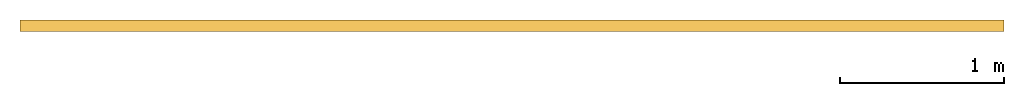
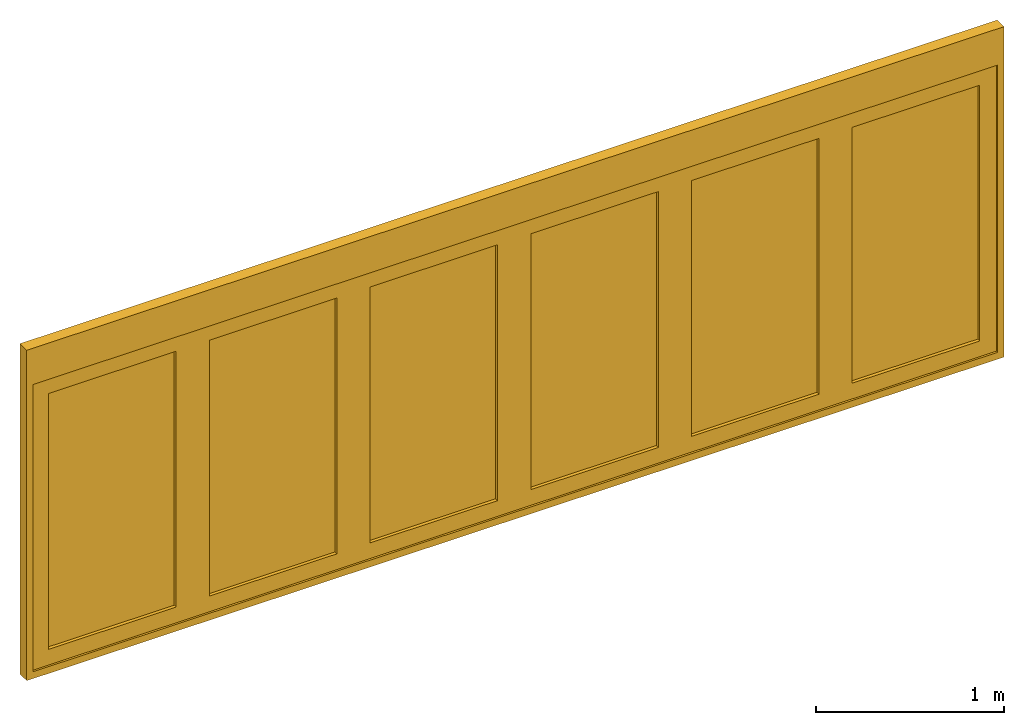
# One storey: 1 door.
"""IFC2X3 building model written with IfcOpenShell, lengths in millimetres."""

from ifc_helpers import new_model, entity, si_unit, converted_unit, direction, frame, frame_2d, origin, place, context, subcontext, project, spatial, polyline, rectangle, outline, extrude, source, transform, mapped, material, material_list, type_object, type_shapes, element, save


model = new_model("IFC2X3")

# Units and contexts
model_context = context("Model", 3, precision=1e-06, world=origin(), true_north=direction((2.0, -1.71512652170913e-15, 1.0)))
context_of_model = context(None, 3, precision=1e-06, world=origin(), true_north=direction((2.0, -1.71512652170913e-15, 1.0)))
body_context = subcontext(model_context, "Body", "Model", "MODEL_VIEW")
ifc_project = project(units=[si_unit("LENGTHUNIT", "METRE", prefix="MILLI"), si_unit("AREAUNIT", "SQUARE_METRE", prefix="MILLI"), si_unit("VOLUMEUNIT", "CUBIC_METRE", prefix="MILLI"), converted_unit("PLANEANGLEUNIT", "DEGREE", entity("IfcRatioMeasure", 0.0174532925199433), si_unit("PLANEANGLEUNIT", "RADIAN"), dimensions=[0, 0, 0, 0, 0, 0, 0]), si_unit("TIMEUNIT", "SECOND")], contexts=[model_context, context_of_model])

# Site, building, storey
site_placement = place(None, origin())
site = spatial("IfcSite", under=ifc_project, at=site_placement, CompositionType="ELEMENT")
building_placement = place(site_placement, origin())
building = spatial("IfcBuilding", under=site, at=building_placement, CompositionType="ELEMENT")
storey_placement = place(building_placement, origin())
storey = spatial("IfcBuildingStorey", under=building, at=storey_placement, Name="Ground Floor", CompositionType="ELEMENT", Elevation=0.0)

# Door
ifc_material_1 = material(Name="Glass-Blue")
ifc_material_2 = material(Name="Mtl-Aluminium")
ifc_material_list = material_list([ifc_material_1, ifc_material_2])
door_style = type_object("IfcDoorStyle", ConstructionType="NOTDEFINED", OperationType="NOTDEFINED", ParameterTakesPrecedence=False, Sizeable=False)
shared_shape = source(origin(), body_context, "Body", "SweptSolid", [
    extrude(rectangle(XDim=782.9333, YDim=18.0, at=frame_2d((5.40012479177676e-13, 1.68753899743024e-14), x_axis=(1.0, 0.0))), frame((6417.14815, 270.45, 101.9), z_axis=(0.0, 0.0, 1.0), x_axis=(-1.0, 0.0, 0.0)), (0.0, 0.0, 1.0), 1660.8),
    extrude(outline(polyline([(-493.366649999999, -932.3), (493.36665, -932.3), (493.36665, 932.3), (-493.366649999999, 932.3), (-493.366649999999, -932.3)]), holes=[polyline([(391.466650000001, 830.4), (391.466650000001, -830.4), (-391.46665, -830.4), (-391.46665, 830.4), (391.466650000001, 830.4)])]), frame((6417.14815, 240.9, 932.3), z_axis=(0.0, 1.0, 0.0), x_axis=(-1.0, 0.0, 0.0)), (0.0, 0.0, 1.0), 59.1),
    extrude(rectangle(XDim=782.933400000001, YDim=18.0, at=frame_2d((5.40012479177676e-13, 1.68753899743024e-14), x_axis=(1.0, 0.0))), frame((5430.4148, 270.45, 101.9), z_axis=(0.0, 0.0, 1.0), x_axis=(-1.0, 0.0, 0.0)), (0.0, 0.0, 1.0), 1660.8),
    extrude(outline(polyline([(-493.366685000001, -932.3), (493.366685, -932.3), (493.366685, 932.3), (-493.366685000001, 932.3), (-493.366685000001, -932.3)]), holes=[polyline([(391.466715, 830.4), (391.466715, -830.4), (-391.466685000001, -830.4), (-391.466685000001, 830.4), (391.466715, 830.4)])]), frame((5430.414815, 240.9, 932.3), z_axis=(0.0, 1.0, 0.0), x_axis=(-1.0, 0.0, 0.0)), (0.0, 0.0, 1.0), 59.1),
    extrude(rectangle(XDim=782.933329999999, YDim=18.0, at=frame_2d((0.0, 1.68753899743024e-14), x_axis=(1.0, 0.0))), frame((4443.681465, 270.45, 101.9), z_axis=(0.0, 0.0, 1.0), x_axis=(-1.0, 0.0, 0.0)), (0.0, 0.0, 1.0), 1660.8),
    extrude(outline(polyline([(-493.366665, -932.3), (493.366665, -932.3), (493.366665, 932.3), (-493.366665, 932.3), (-493.366665, -932.3)]), holes=[polyline([(391.466665, 830.4), (391.466665, -830.4), (-391.466665, -830.4), (-391.466665, 830.4), (391.466665, 830.4)])]), frame((4443.681465, 240.9, 932.3), z_axis=(0.0, 1.0, 0.0), x_axis=(-1.0, 0.0, 0.0)), (0.0, 0.0, 1.0), 59.1),
    extrude(rectangle(XDim=782.93333, YDim=18.0, at=frame_2d((2.55795384873636e-13, 1.68753899743024e-14), x_axis=(1.0, 0.0))), frame((3456.948135, 270.45, 101.9), z_axis=(0.0, 0.0, 1.0), x_axis=(-1.0, 0.0, 0.0)), (0.0, 0.0, 1.0), 1660.8),
    extrude(outline(polyline([(-493.366665, -932.3), (493.366665, -932.3), (493.366665, 932.3), (-493.366665, 932.3), (-493.366665, -932.3)]), holes=[polyline([(391.466665, 830.4), (391.466665, -830.4), (-391.466665, -830.4), (-391.466665, 830.4), (391.466665, 830.4)])]), frame((3456.948135, 240.9, 932.3), z_axis=(0.0, 1.0, 0.0), x_axis=(-1.0, 0.0, 0.0)), (0.0, 0.0, 1.0), 59.1),
    extrude(rectangle(XDim=782.9334, YDim=18.0, at=frame_2d((0.0, 1.68753899743024e-14), x_axis=(1.0, 0.0))), frame((2470.2148, 270.45, 101.9), z_axis=(0.0, 0.0, 1.0), x_axis=(-1.0, 0.0, 0.0)), (0.0, 0.0, 1.0), 1660.8),
    extrude(outline(polyline([(-493.366685, -932.3), (493.366685, -932.3), (493.366685, 932.3), (-493.366685, 932.3), (-493.366685, -932.3)]), holes=[polyline([(391.466685000001, 830.4), (391.466685000001, -830.4), (-391.466715, -830.4), (-391.466715, 830.4), (391.466685000001, 830.4)])]), frame((2470.214785, 240.9, 932.3), z_axis=(0.0, 1.0, 0.0), x_axis=(-1.0, 0.0, 0.0)), (0.0, 0.0, 1.0), 59.1),
    extrude(rectangle(XDim=782.9333, YDim=18.0, at=frame_2d((-1.4210854715202e-13, 1.68753899743024e-14), x_axis=(1.0, 0.0))), frame((1483.48145, 270.45, 101.9), z_axis=(0.0, 0.0, 1.0), x_axis=(-1.0, 0.0, 0.0)), (0.0, 0.0, 1.0), 1660.8),
    extrude(outline(polyline([(-493.36665, -932.3), (493.36665, -932.3), (493.36665, 932.3), (-493.36665, 932.3), (-493.36665, -932.3)]), holes=[polyline([(391.46665, 830.4), (391.46665, -830.4), (-391.46665, -830.4), (-391.46665, 830.4), (391.46665, 830.4)])]), frame((1483.48145, 240.9, 932.3), z_axis=(0.0, 1.0, 0.0), x_axis=(-1.0, 0.0, 0.0)), (0.0, 0.0, 1.0), 59.1),
    extrude(rectangle(XDim=39.8000000000002, YDim=71.6, at=frame_2d((0.0, 1.77635683940025e-14), x_axis=(1.0, 0.0))), frame((970.2148, 264.2, 0.0), z_axis=(0.0, 0.0, 1.0), x_axis=(-1.0, 0.0, 0.0)), (0.0, 0.0, 1.0), 1864.6),
    extrude(rectangle(XDim=39.7999999999996, YDim=71.6, at=frame_2d((0.0, 1.77635683940025e-14), x_axis=(1.0, 0.0))), frame((6930.4148, 264.2, 0.0), z_axis=(0.0, 0.0, 1.0), x_axis=(-1.0, 0.0, 0.0)), (0.0, 0.0, 1.0), 1864.6),
    extrude(rectangle(XDim=6000.0, YDim=71.6, at=frame_2d((0.0, 1.77635683940025e-14), x_axis=(1.0, 0.0))), frame((3950.3148, 264.2, 1864.6), z_axis=(0.0, 0.0, 1.0), x_axis=(-1.0, 0.0, 0.0)), (0.0, 0.0, 1.0), 235.4),
    extrude(rectangle(XDim=6000.0, YDim=71.6, at=frame_2d((0.0, 1.77635683940025e-14), x_axis=(1.0, 0.0))), frame((3950.3148, 264.2, -44.6), z_axis=(0.0, 0.0, 1.0), x_axis=(-1.0, 0.0, 0.0)), (0.0, 0.0, 1.0), 44.6),
])
type_shapes(door_style, [shared_shape])
door_placement = place(storey_placement, origin())
element("IfcDoor", 1, at=door_placement, inside=storey, type_object=door_style, material=ifc_material_list, OverallHeight=2144.6, OverallWidth=6000.0, context=body_context, shape_type="MappedRepresentation", body=[
    mapped(shared_shape, transform((0.0, 0.0, 0.0), scale=1.0)),
])

save(model, "model.ifc")
